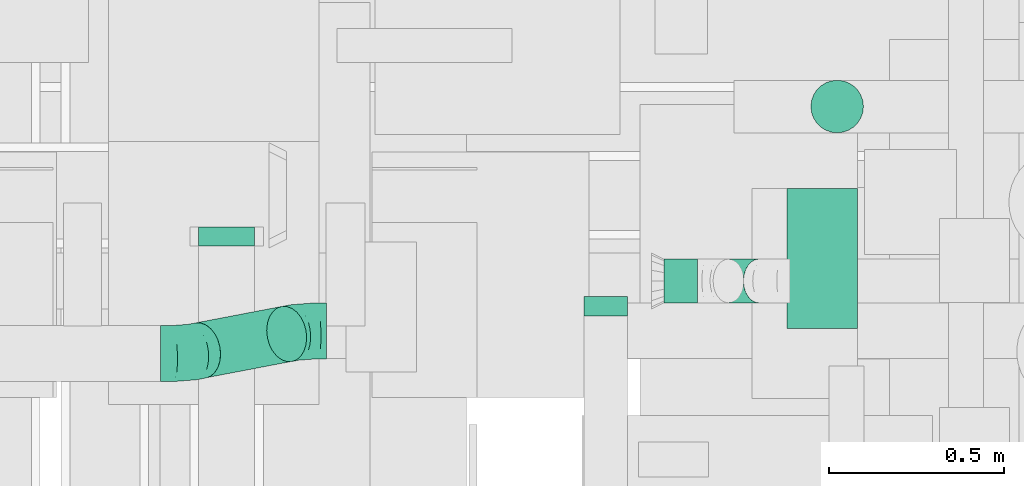
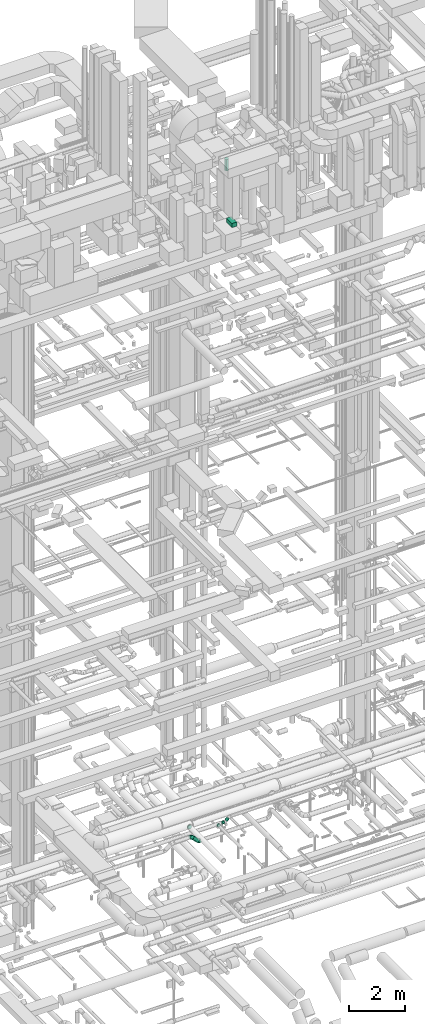
# One storey, part 183 of 337: 5 flow segments, 4 flow fittings.
"""IFC2X3 building model written with IfcOpenShell, lengths in millimetres."""

import ifcopenshell
import ifcopenshell.guid

model = None  # the IFC model being written
_history = None  # IfcOwnerHistory: only IFC2X3 demands one
_inside = {}  # id of a spatial element -> (the spatial element, [elements in it])
_under = {}  # id of a project, library or spatial element -> (it, [spatial elements below it])
_declared = {}  # id of a project -> (the project, [libraries it declares])
_typed = {}  # id of a type object -> (the type object, [elements of that type])
_made_of = {}  # id of a material, layer set ... -> (it, [elements and type objects made of it])


def new_model(schema):
    """Start an empty IFC model of exactly this schema.

    Asked for "IFC4X3", IfcOpenShell would pick the latest addendum, in which some entities
    have other attributes; the version numbers below select the first issue.
    IFC2X3 requires an IfcOwnerHistory on every rooted entity: one is made here for all.
    """
    global model, _history
    if schema == "IFC4X3":
        model = ifcopenshell.file(schema_version=(4, 3, 0, 0))
    else:
        model = ifcopenshell.file(schema=schema)
    _inside.clear()
    _under.clear()
    _declared.clear()
    _typed.clear()
    _made_of.clear()
    _history = None
    if model.schema == "IFC2X3":
        org = make("IfcOrganization", Name="unknown")
        user = make(
            "IfcPersonAndOrganization",
            ThePerson=make("IfcPerson", FamilyName="unknown"),
            TheOrganization=org,
        )
        app = make(
            "IfcApplication",
            ApplicationDeveloper=org,
            Version="unknown",
            ApplicationFullName="unknown",
            ApplicationIdentifier="unknown",
        )
        _history = make(
            "IfcOwnerHistory",
            OwningUser=user,
            OwningApplication=app,
            ChangeAction="ADDED",
            CreationDate=0,
        )
    return model


def make(cls, **values):
    """One entity of the class cls with the attributes given. An attribute that is None is left unset."""
    return model.create_entity(
        cls, **{name: value for name, value in values.items() if value is not None}
    )


def entity(cls, *values):
    """Any entity or typed value of the class cls, its attributes in the order of the schema. None: left unset."""
    e = model.create_entity(cls)
    for i, value in enumerate(values):
        if value is not None:
            e[i] = value
    return e


def rooted(cls, **values):
    """An entity with a GlobalId (a new one), such as an element, a storey or a relation."""
    return make(cls, GlobalId=ifcopenshell.guid.new(), OwnerHistory=_history, **values)


def si_unit(unit_type, name, prefix=None):
    """IfcSIUnit, for example si_unit("LENGTHUNIT", "METRE", prefix="MILLI")."""
    return make("IfcSIUnit", UnitType=unit_type, Prefix=prefix, Name=name)


def converted_unit(unit_type, name, factor, base, dimensions=None, offset=None):
    """IfcConversionBasedUnit, such as the inch: factor (a typed value) times the base unit."""
    return make(
        "IfcConversionBasedUnit"
        if offset is None
        else "IfcConversionBasedUnitWithOffset",
        ConversionOffset=offset,
        Dimensions=None
        if dimensions is None
        else entity("IfcDimensionalExponents", *dimensions),
        UnitType=unit_type,
        Name=name,
        ConversionFactor=make(
            "IfcMeasureWithUnit", ValueComponent=factor, UnitComponent=base
        ),
    )


def derived_unit(unit_type, elements):
    """IfcDerivedUnit: a product of units, each with its exponent."""
    return make(
        "IfcDerivedUnit",
        Elements=[
            make("IfcDerivedUnitElement", Unit=unit, Exponent=power)
            for unit, power in elements
        ],
        UnitType=unit_type,
    )


def assignment(units):
    """IfcUnitAssignment: the units of a project."""
    return None if units is None else make("IfcUnitAssignment", Units=units)


def point(xyz):
    """IfcCartesianPoint."""
    return None if xyz is None else make("IfcCartesianPoint", Coordinates=xyz)


def direction(xyz):
    """IfcDirection."""
    return None if xyz is None else make("IfcDirection", DirectionRatios=xyz)


def frame(location, z_axis=None, x_axis=None):
    """IfcAxis2Placement3D, a coordinate frame: its origin and axes. An axis left out is left unset."""
    return make(
        "IfcAxis2Placement3D",
        Location=point(location),
        Axis=direction(z_axis),
        RefDirection=direction(x_axis),
    )


def frame_2d(location, x_axis=None):
    """IfcAxis2Placement2D, a coordinate frame in the plane: its origin and x axis."""
    return make(
        "IfcAxis2Placement2D", Location=point(location), RefDirection=direction(x_axis)
    )


def origin():
    """The frame at (0, 0, 0) with its axes left unset."""
    return frame((0.0, 0.0, 0.0))


def origin_2d_with_axis():
    """The frame at (0, 0) in the plane with the x axis (1, 0) written out."""
    return frame_2d((0.0, 0.0), x_axis=(1.0, 0.0))


def place(relative_to, where):
    """IfcLocalPlacement: puts the frame where relative to a parent placement (None: the world)."""
    return make(
        "IfcLocalPlacement", PlacementRelTo=relative_to, RelativePlacement=where
    )


def context(
    kind, dimensions, precision=None, world=None, true_north=None, identifier=None
):
    """IfcGeometricRepresentationContext, for example the 3D "Model" context."""
    return make(
        "IfcGeometricRepresentationContext",
        ContextIdentifier=identifier,
        ContextType=kind,
        CoordinateSpaceDimension=dimensions,
        Precision=precision,
        WorldCoordinateSystem=world,
        TrueNorth=true_north,
    )


def subcontext(parent, identifier, kind, view, scale=None):
    """IfcGeometricRepresentationSubContext, for example "Body" below "Model"."""
    return make(
        "IfcGeometricRepresentationSubContext",
        ContextIdentifier=identifier,
        ContextType=kind,
        ParentContext=parent,
        TargetScale=scale,
        TargetView=view,
    )


def project(units=None, contexts=None):
    """IfcProject with its units and contexts."""
    return rooted(
        "IfcProject",
        Name="project",
        RepresentationContexts=contexts,
        UnitsInContext=assignment(units),
    )


def spatial(cls, under=None, at=None, **own):
    """A site, building, storey or space (cls), placed at a placement, below another one or the project."""
    s = rooted(cls, ObjectPlacement=at, **own)
    if under is not None:
        _under.setdefault(under.id(), (under, []))[1].append(s)
    return s


def profile(cls, at=None, kind="AREA", **sizes):
    """A parametric profile (cls). Its sizes go by their IFC names, for example OverallWidth=200.0."""
    return make(cls, ProfileType=kind, Position=at, **sizes)


def rectangle(**sizes):
    """IfcRectangleProfileDef."""
    return profile("IfcRectangleProfileDef", **sizes)


def circle(**sizes):
    """IfcCircleProfileDef."""
    return profile("IfcCircleProfileDef", **sizes)


def extrude(swept, where, along, depth):
    """IfcExtrudedAreaSolid: the profile swept, set in the frame where, extruded along a direction by depth."""
    return make(
        "IfcExtrudedAreaSolid",
        SweptArea=swept,
        Position=where,
        ExtrudedDirection=direction(along),
        Depth=depth,
    )


def faces_of(points, faces, orient=None, outer=None):
    """IfcFace entities. A face is a list of loops; a loop is a list of indices into points, from 0.

    orient and outer hold one flag for each loop. By default every Orientation is true, the
    first loop of a face is its IfcFaceOuterBound and the others are IfcFaceBound.
    """
    made = []
    for i, loops in enumerate(faces):
        bounds = []
        for j, loop in enumerate(loops):
            is_outer = j == 0 if outer is None else outer[i][j]
            bounds.append(
                make(
                    "IfcFaceOuterBound" if is_outer else "IfcFaceBound",
                    Bound=make("IfcPolyLoop", Polygon=[points[k] for k in loop]),
                    Orientation=True if orient is None else orient[i][j],
                )
            )
        made.append(make("IfcFace", Bounds=bounds))
    return made


def faceted_brep(points, faces, orient=None, outer=None, voids=None):
    """IfcFacetedBrep: a solid bounded by flat faces; with voids (closed shells), ...WithVoids."""
    shared = [point(p) for p in points]
    hull = make("IfcClosedShell", CfsFaces=faces_of(shared, faces, orient, outer))
    if voids is None:
        return make("IfcFacetedBrep", Outer=hull)
    return make(
        "IfcFacetedBrepWithVoids",
        Outer=hull,
        Voids=[
            make(cls, CfsFaces=faces_of(shared, fs, o, b)) for cls, fs, o, b in voids
        ],
    )


def shape(context_of_items, identifier, shape_type, items):
    """IfcShapeRepresentation: the items that make up one representation, for example the "Body"."""
    return make(
        "IfcShapeRepresentation",
        ContextOfItems=context_of_items,
        RepresentationIdentifier=identifier,
        RepresentationType=shape_type,
        Items=items,
    )


def source(mapping_origin, context_of_items, identifier, shape_type, items):
    """IfcRepresentationMap: a shape defined once, which mapped items show again and again."""
    return make(
        "IfcRepresentationMap",
        MappingOrigin=mapping_origin,
        MappedRepresentation=shape(context_of_items, identifier, shape_type, items),
    )


def transform(
    local_origin,
    x_axis=None,
    y_axis=None,
    z_axis=None,
    scale=None,
    scale2=None,
    scale3=None,
    uniform=True,
):
    """IfcCartesianTransformationOperator3D, or its non-uniform kind. x_axis, y_axis, z_axis: its Axis1, 2, 3."""
    if uniform:
        return make(
            "IfcCartesianTransformationOperator3D",
            Axis1=direction(x_axis),
            Axis2=direction(y_axis),
            LocalOrigin=point(local_origin),
            Scale=scale,
            Axis3=direction(z_axis),
        )
    return make(
        "IfcCartesianTransformationOperator3DnonUniform",
        Axis1=direction(x_axis),
        Axis2=direction(y_axis),
        LocalOrigin=point(local_origin),
        Scale=scale,
        Axis3=direction(z_axis),
        Scale2=scale2,
        Scale3=scale3,
    )


def mapped(mapping_source, mapping_target):
    """IfcMappedItem: shows the shape of a source again, moved by a transform."""
    return make(
        "IfcMappedItem", MappingSource=mapping_source, MappingTarget=mapping_target
    )


def material(Name=None, Category=None):
    """IfcMaterial."""
    return make("IfcMaterial", Name=Name, Category=Category)


def made_of(thing, what):
    """Note that an element or type object is made of a material, layer set ...; save() writes the relation."""
    if what is not None:
        _made_of.setdefault(what.id(), (what, []))[1].append(thing)
    return thing


def type_object(cls, material=None, **own):
    """A type object (cls), such as IfcWallType, which elements share."""
    return made_of(rooted(cls, **own), material)


def type_shapes(of_type, sources):
    """Give a type object the sources (RepresentationMaps) that its elements show as mapped items."""
    of_type.RepresentationMaps = sources


def element(
    cls,
    number,
    at=None,
    inside=None,
    cuts=None,
    type_object=None,
    material=None,
    context=None,
    identifier="Body",
    shape_type=None,
    held_by="IfcProductDefinitionShape",
    body=None,
    shapes=None,
    **own,
):
    """One element of the class cls, such as IfcWall. Its Tag is "e" and its number.

    at: its placement. inside: the storey or other place that contains it. cuts: it is an
    opening in that element (IfcRelVoidsElement). A single representation is given by context,
    identifier, shape_type and body (its items); several are given by shapes. held_by: the class
    of the entity that holds the representations. save() writes the other relations.
    """
    e = rooted(cls, Tag="e%d" % number, ObjectPlacement=at, **own)
    if body is not None:
        shapes = [shape(context, identifier, shape_type, body)]
    if shapes is not None:
        e.Representation = make(held_by, Representations=shapes)
    if inside is not None:
        _inside.setdefault(inside.id(), (inside, []))[1].append(e)
    if cuts is not None:
        rooted(
            "IfcRelVoidsElement", RelatingBuildingElement=cuts, RelatedOpeningElement=e
        )
    if type_object is not None:
        _typed.setdefault(type_object.id(), (type_object, []))[1].append(e)
    return made_of(e, material)


def aggregate(whole, parts):
    """IfcRelAggregates: a whole, such as a stair, and the parts it consists of."""
    return rooted("IfcRelAggregates", RelatingObject=whole, RelatedObjects=parts)


def save(model, path):
    """Write the relations noted so far, then the file.

    IfcRelAggregates (storeys below a building ...), IfcRelContainedInSpatialStructure (elements
    in a storey), IfcRelDefinesByType, IfcRelAssociatesMaterial and IfcRelDeclares: one each for
    every whole, place, type object, material and project.
    """
    for whole, parts in _under.values():
        aggregate(whole, parts)
    for where, things in _inside.values():
        rooted(
            "IfcRelContainedInSpatialStructure",
            RelatedElements=things,
            RelatingStructure=where,
        )
    for kind, things in _typed.values():
        rooted("IfcRelDefinesByType", RelatedObjects=things, RelatingType=kind)
    for what, things in _made_of.values():
        rooted("IfcRelAssociatesMaterial", RelatedObjects=things, RelatingMaterial=what)
    for by, libraries in _declared.values():
        rooted("IfcRelDeclares", RelatingContext=by, RelatedDefinitions=libraries)
    model.write(path)


model = new_model("IFC2X3")

# Units and contexts
model_context = context("Model", 3, precision=0.01, world=origin(), true_north=direction((6.12303176911189e-17, 1.0)))
body_context = subcontext(model_context, "Body", "Model", "MODEL_VIEW")
ifc_project = project(units=[si_unit("LENGTHUNIT", "METRE", prefix="MILLI"), si_unit("AREAUNIT", "SQUARE_METRE"), si_unit("VOLUMEUNIT", "CUBIC_METRE"), converted_unit("PLANEANGLEUNIT", "DEGREE", entity("IfcRatioMeasure", 0.0174532925199433), si_unit("PLANEANGLEUNIT", "RADIAN"), dimensions=[0, 0, 0, 0, 0, 0, 0]), si_unit("MASSUNIT", "GRAM", prefix="KILO"), derived_unit("MASSDENSITYUNIT", [(si_unit("MASSUNIT", "GRAM", prefix="KILO"), 1), (si_unit("LENGTHUNIT", "METRE"), -3)]), derived_unit("MOMENTOFINERTIAUNIT", [(si_unit("LENGTHUNIT", "METRE"), 4)]), si_unit("TIMEUNIT", "SECOND"), si_unit("FREQUENCYUNIT", "HERTZ"), si_unit("THERMODYNAMICTEMPERATUREUNIT", "DEGREE_CELSIUS"), derived_unit("THERMALTRANSMITTANCEUNIT", [(si_unit("MASSUNIT", "GRAM", prefix="KILO"), 1), (si_unit("THERMODYNAMICTEMPERATUREUNIT", "KELVIN"), -1), (si_unit("TIMEUNIT", "SECOND"), -3)]), derived_unit("VOLUMETRICFLOWRATEUNIT", [(si_unit("LENGTHUNIT", "METRE"), 3), (si_unit("TIMEUNIT", "SECOND"), -1)]), derived_unit("MASSFLOWRATEUNIT", [(si_unit("MASSUNIT", "GRAM", prefix="KILO"), 1), (si_unit("TIMEUNIT", "SECOND"), -1)]), derived_unit("ROTATIONALFREQUENCYUNIT", [(si_unit("TIMEUNIT", "SECOND"), -1)]), si_unit("ELECTRICCURRENTUNIT", "AMPERE"), si_unit("ELECTRICVOLTAGEUNIT", "VOLT"), si_unit("POWERUNIT", "WATT"), si_unit("FORCEUNIT", "NEWTON", prefix="KILO"), si_unit("ILLUMINANCEUNIT", "LUX"), si_unit("LUMINOUSFLUXUNIT", "LUMEN"), si_unit("LUMINOUSINTENSITYUNIT", "CANDELA"), derived_unit("USERDEFINED", [(si_unit("MASSUNIT", "GRAM", prefix="KILO"), -1), (si_unit("LENGTHUNIT", "METRE"), -2), (si_unit("TIMEUNIT", "SECOND"), 3), (si_unit("LUMINOUSFLUXUNIT", "LUMEN"), 1)]), derived_unit("LINEARVELOCITYUNIT", [(si_unit("LENGTHUNIT", "METRE"), 1), (si_unit("TIMEUNIT", "SECOND"), -1)]), si_unit("PRESSUREUNIT", "PASCAL"), derived_unit("USERDEFINED", [(si_unit("LENGTHUNIT", "METRE"), -2), (si_unit("MASSUNIT", "GRAM", prefix="KILO"), 1), (si_unit("TIMEUNIT", "SECOND"), -2)]), derived_unit("LINEARFORCEUNIT", [(si_unit("MASSUNIT", "GRAM", prefix="KILO"), 1), (si_unit("LENGTHUNIT", "METRE"), 1), (si_unit("TIMEUNIT", "SECOND"), -2), (si_unit("LENGTHUNIT", "METRE"), -1)]), derived_unit("PLANARFORCEUNIT", [(si_unit("MASSUNIT", "GRAM", prefix="KILO"), 1), (si_unit("LENGTHUNIT", "METRE"), 1), (si_unit("TIMEUNIT", "SECOND"), -2), (si_unit("LENGTHUNIT", "METRE"), -2)])], contexts=[model_context])

# Site, building, storey
site_placement = place(None, origin())
site = spatial("IfcSite", under=ifc_project, at=site_placement, CompositionType="ELEMENT")
building_placement = place(site_placement, origin())
building = spatial("IfcBuilding", under=site, at=building_placement, CompositionType="ELEMENT")
storey_placement = place(building_placement, origin())
storey = spatial("IfcBuildingStorey", under=building, at=storey_placement, CompositionType="ELEMENT", Elevation=0.0)

# Flow segments
duct_segment_type_1 = type_object("IfcDuctSegmentType", PredefinedType="NOTDEFINED")
flow_segment_1_placement = place(storey_placement, frame((52010.61, 8206.69, 29120.0)))
element("IfcFlowSegment", 1, at=flow_segment_1_placement, inside=storey, type_object=duct_segment_type_1, context=body_context, shape_type="SweptSolid", body=[
    extrude(rectangle(XDim=200.000000000007, YDim=400.0, at=origin_2d_with_axis()), frame((100.0, 200.0, 0.0)), (0.0, 0.0, 1.0), 177.000000000337),
])
duct_segment_type_2 = type_object("IfcDuctSegmentType", PredefinedType="NOTDEFINED")
flow_segment_2_placement = place(storey_placement, frame((52076.59, 8763.9, 31208.0)))
element("IfcFlowSegment", 2, at=flow_segment_2_placement, inside=storey, type_object=duct_segment_type_2, context=body_context, shape_type="SweptSolid", body=[
    extrude(circle(Radius=75.0, at=origin_2d_with_axis()), frame((76.6, 76.6, 0.0)), (0.0, 0.0, 1.0), 497.002731163141),
])
flow_segment_3_placement = place(storey_placement, frame((50277.05, 8063.8, 2888.36)))
element("IfcFlowSegment", 3, at=flow_segment_3_placement, inside=storey, type_object=duct_segment_type_2, context=body_context, shape_type="SweptSolid", body=[
    extrude(circle(Radius=80.0, at=origin_2d_with_axis()), frame((304.61, 127.24, 58.67), z_axis=(-0.700733092058318, -0.133963679364098, 0.700733092058326), x_axis=(-0.18777580730125, 0.98221191511423, 0.0)), (0.0, 0.0, 1.0), 350.972539327525),
])
flow_segment_4_placement = place(storey_placement, frame((51658.34, 8278.42, 3175.9)))
element("IfcFlowSegment", 4, at=flow_segment_4_placement, inside=storey, type_object=duct_segment_type_2, context=body_context, shape_type="SweptSolid", body=[
    extrude(circle(Radius=62.5, at=origin_2d_with_axis()), frame((0.0, 64.1, 64.1), z_axis=(1.0, 0.0, 0.0), x_axis=(0.0, -1.0, 0.0)), (0.0, 0.0, 1.0), 96.4430691768214),
])
flow_segment_5_placement = place(storey_placement, frame((51797.39, 8278.42, 3230.82)))
element("IfcFlowSegment", 5, at=flow_segment_5_placement, inside=storey, type_object=duct_segment_type_2, context=body_context, shape_type="SweptSolid", body=[
    extrude(circle(Radius=62.5, at=origin_2d_with_axis()), frame((45.79, 64.1, 45.79), z_axis=(0.707106523092433, 0.0, 0.707107039280568), x_axis=(0.0, -1.0, 0.0)), (0.0, 0.0, 1.0), 122.720643343335),
])

# Flow fittings
ifc_material = material()
duct_fitting_type_1 = type_object("IfcDuctFittingType", PredefinedType="NOTDEFINED", material=ifc_material)
shared_shape_1 = source(origin(), body_context, "Body", "Brep", [
    faceted_brep([(20.0, 16.18, -60.37), (20.0, 31.25, -54.13), (20.0, 44.19, -44.19), (20.0, 54.13, -31.25), (20.0, 60.37, -16.18), (20.0, 62.5, 0.0), (20.0, 60.37, 16.18), (20.0, 54.13, 31.25), (20.0, 44.19, 44.19), (20.0, 31.25, 54.13), (20.0, 16.18, 60.37), (20.0, 0.0, 62.5), (20.0, -16.18, 60.37), (20.0, -31.25, 54.13), (20.0, -44.19, 44.19), (20.0, -54.13, 31.25), (20.0, -60.37, 16.18), (20.0, -62.5, 0.0), (20.0, -60.37, -16.18), (20.0, -54.13, -31.25), (20.0, -44.19, -44.19), (20.0, -31.25, -54.13), (20.0, -16.18, -60.37), (20.0, 0.0, -62.5), (0.0, 0.0, 62.5), (0.0, 16.18, 60.37), (-36.16, 16.18, 60.37), (-36.16, 0.0, 62.5), (0.0, 31.25, 54.13), (-36.16, 31.25, 54.13), (0.0, 44.19, 44.19), (-36.16, 44.19, 44.19), (0.0, 54.13, 31.25), (0.0, 60.37, 16.18), (-36.16, 60.37, 16.18), (-36.16, 54.13, 31.25), (0.0, 62.5, 0.0), (-36.16, 62.5, 0.0), (0.0, 60.37, -16.18), (-36.16, 60.37, -16.18), (0.0, 54.13, -31.25), (-36.16, 54.13, -31.25), (0.0, 44.19, -44.19), (-36.16, 44.19, -44.19), (0.0, 31.25, -54.13), (0.0, 16.18, -60.37), (-36.16, 16.18, -60.37), (-36.16, 31.25, -54.13), (0.0, 0.0, -62.5), (-36.16, 0.0, -62.5), (0.0, -16.18, -60.37), (-36.16, -16.18, -60.37), (0.0, -31.25, -54.13), (-36.16, -31.25, -54.13), (0.0, -44.19, -44.19), (-36.16, -44.19, -44.19), (0.0, -54.13, -31.25), (0.0, -60.37, -16.18), (-36.16, -60.37, -16.18), (-36.16, -54.13, -31.25), (0.0, -62.5, 0.0), (-36.16, -62.5, 0.0), (0.0, -60.37, 16.18), (-36.16, -60.37, 16.18), (0.0, -54.13, 31.25), (-36.16, -54.13, 31.25), (0.0, -44.19, 44.19), (-36.16, -44.19, 44.19), (0.0, -31.25, 54.13), (0.0, -16.18, 60.37), (-36.16, -16.18, 60.37), (-36.16, -31.25, 54.13)], [[[0, 1, 2, 3, 4, 5, 6, 7, 8, 9, 10, 11, 12, 13, 14, 15, 16, 17, 18, 19, 20, 21, 22, 23]], [[24, 11, 10, 25, 26, 27]], [[25, 10, 9, 28, 29, 26]], [[28, 9, 8, 30, 31, 29]], [[32, 7, 6, 33, 34, 35]], [[33, 6, 5, 36, 37, 34]], [[30, 8, 7, 32, 35, 31]], [[36, 5, 4, 38, 39, 37]], [[38, 4, 3, 40, 41, 39]], [[40, 3, 2, 42, 43, 41]], [[44, 1, 0, 45, 46, 47]], [[45, 0, 23, 48, 49, 46]], [[42, 2, 1, 44, 47, 43]], [[48, 23, 22, 50, 51, 49]], [[50, 22, 21, 52, 53, 51]], [[52, 21, 20, 54, 55, 53]], [[56, 19, 18, 57, 58, 59]], [[57, 18, 17, 60, 61, 58]], [[54, 20, 19, 56, 59, 55]], [[60, 17, 16, 62, 63, 61]], [[62, 16, 15, 64, 65, 63]], [[64, 15, 14, 66, 67, 65]], [[68, 13, 12, 69, 70, 71]], [[69, 12, 11, 24, 27, 70]], [[66, 14, 13, 68, 71, 67]], [[49, 51, 53, 55, 59, 58, 61, 63, 65, 67, 71, 70, 27, 26, 29, 31, 35, 34, 37, 39, 41, 43, 47, 46]]]),
])
type_shapes(duct_fitting_type_1, [shared_shape_1])
flow_fitting_1_placement = place(storey_placement, frame((51492.68, 8262.51, 3240.0), z_axis=(0.0, 0.0, -1.0), x_axis=(0.0, -1.0, 0.0)))
element("IfcFlowFitting", 6, at=flow_fitting_1_placement, inside=storey, type_object=duct_fitting_type_1, material=ifc_material, context=body_context, shape_type="MappedRepresentation", body=[
    mapped(shared_shape_1, transform((0.0, 0.0, 0.0), scale=1.0)),
])
duct_fitting_type_2 = type_object("IfcDuctFittingType", PredefinedType="NOTDEFINED", material=ifc_material)
shared_shape_2 = source(origin(), body_context, "Body", "Brep", [
    faceted_brep([(20.0, 20.71, -77.27), (20.0, 40.0, -69.28), (20.0, 56.57, -56.57), (20.0, 69.28, -40.0), (20.0, 77.27, -20.71), (20.0, 80.0, 0.0), (20.0, 77.27, 20.71), (20.0, 69.28, 40.0), (20.0, 56.57, 56.57), (20.0, 40.0, 69.28), (20.0, 20.71, 77.27), (20.0, 0.0, 80.0), (20.0, -20.71, 77.27), (20.0, -40.0, 69.28), (20.0, -56.57, 56.57), (20.0, -69.28, 40.0), (20.0, -77.27, 20.71), (20.0, -80.0, 0.0), (20.0, -77.27, -20.71), (20.0, -69.28, -40.0), (20.0, -56.57, -56.57), (20.0, -40.0, -69.28), (20.0, -20.71, -77.27), (20.0, 0.0, -80.0), (0.0, 0.0, 80.0), (0.0, 20.71, 77.27), (-35.05, 20.71, 77.27), (-35.05, 0.0, 80.0), (0.0, 40.0, 69.28), (-35.05, 40.0, 69.28), (0.0, 56.57, 56.57), (-35.05, 56.57, 56.57), (0.0, 69.28, 40.0), (0.0, 77.27, 20.71), (-35.05, 77.27, 20.71), (-35.05, 69.28, 40.0), (0.0, 80.0, 0.0), (-35.05, 80.0, 0.0), (0.0, 77.27, -20.71), (-35.05, 77.27, -20.71), (0.0, 69.28, -40.0), (-35.05, 69.28, -40.0), (0.0, 56.57, -56.57), (-35.05, 56.57, -56.57), (0.0, 40.0, -69.28), (0.0, 20.71, -77.27), (-35.05, 20.71, -77.27), (-35.05, 40.0, -69.28), (0.0, 0.0, -80.0), (-35.05, 0.0, -80.0), (0.0, -20.71, -77.27), (-35.05, -20.71, -77.27), (0.0, -40.0, -69.28), (-35.05, -40.0, -69.28), (0.0, -56.57, -56.57), (-35.05, -56.57, -56.57), (0.0, -69.28, -40.0), (0.0, -77.27, -20.71), (-35.05, -77.27, -20.71), (-35.05, -69.28, -40.0), (0.0, -80.0, 0.0), (-35.05, -80.0, 0.0), (0.0, -77.27, 20.71), (-35.05, -77.27, 20.71), (0.0, -69.28, 40.0), (-35.05, -69.28, 40.0), (0.0, -56.57, 56.57), (-35.05, -56.57, 56.57), (0.0, -40.0, 69.28), (0.0, -20.71, 77.27), (-35.05, -20.71, 77.27), (-35.05, -40.0, 69.28)], [[[0, 1, 2, 3, 4, 5, 6, 7, 8, 9, 10, 11, 12, 13, 14, 15, 16, 17, 18, 19, 20, 21, 22, 23]], [[24, 11, 10, 25, 26, 27]], [[25, 10, 9, 28, 29, 26]], [[28, 9, 8, 30, 31, 29]], [[32, 7, 6, 33, 34, 35]], [[33, 6, 5, 36, 37, 34]], [[30, 8, 7, 32, 35, 31]], [[36, 5, 4, 38, 39, 37]], [[38, 4, 3, 40, 41, 39]], [[40, 3, 2, 42, 43, 41]], [[44, 1, 0, 45, 46, 47]], [[45, 0, 23, 48, 49, 46]], [[42, 2, 1, 44, 47, 43]], [[48, 23, 22, 50, 51, 49]], [[50, 22, 21, 52, 53, 51]], [[52, 21, 20, 54, 55, 53]], [[56, 19, 18, 57, 58, 59]], [[57, 18, 17, 60, 61, 58]], [[54, 20, 19, 56, 59, 55]], [[60, 17, 16, 62, 63, 61]], [[62, 16, 15, 64, 65, 63]], [[64, 15, 14, 66, 67, 65]], [[68, 13, 12, 69, 70, 71]], [[69, 12, 11, 24, 27, 70]], [[66, 14, 13, 68, 71, 67]], [[49, 51, 53, 55, 59, 58, 61, 63, 65, 67, 71, 70, 27, 26, 29, 31, 35, 34, 37, 39, 41, 43, 47, 46]]]),
])
type_shapes(duct_fitting_type_2, [shared_shape_2])
flow_fitting_2_placement = place(storey_placement, frame((50409.85, 8461.67, 3425.0), z_axis=(0.0, 0.0, -1.0), x_axis=(0.0, -1.0, 0.0)))
element("IfcFlowFitting", 7, at=flow_fitting_2_placement, inside=storey, type_object=duct_fitting_type_2, material=ifc_material, context=body_context, shape_type="MappedRepresentation", body=[
    mapped(shared_shape_2, transform((0.0, 0.0, 0.0), scale=1.0)),
])
duct_fitting_type_3 = type_object("IfcDuctFittingType", PredefinedType="NOTDEFINED", material=ifc_material)
shared_shape_3 = source(origin(), body_context, "Body", "Brep", [
    faceted_brep([(-67.12, 0.0, -80.0), (-67.12, -20.71, -77.27), (-67.12, -40.0, -69.28), (-67.12, -56.57, -56.57), (-67.12, -69.28, -40.0), (-67.12, -77.27, -20.71), (-67.12, -80.0, 0.0), (-67.12, -77.27, 20.71), (-67.12, -69.28, 40.0), (-67.12, -56.57, 56.57), (-67.12, -40.0, 69.28), (-67.12, -20.71, 77.27), (-67.12, 0.0, 80.0), (-67.12, 20.71, 77.27), (-67.12, 40.0, 69.28), (-67.12, 56.57, 56.57), (-67.12, 69.28, 40.0), (-67.12, 77.27, 20.71), (-67.12, 80.0, 0.0), (-67.12, 77.27, -20.71), (-67.12, 69.28, -40.0), (-67.12, 56.57, -56.57), (-67.12, 40.0, -69.28), (-67.12, 20.71, -77.27), (-39.08, 20.71, 77.27), (-42.97, 40.0, 69.28), (-34.92, 0.0, 80.0), (-46.3, 56.57, 56.57), (-50.47, 77.27, 20.71), (-51.02, 80.0, 0.0), (-48.86, 69.28, 40.0), (-48.86, 69.28, -40.0), (-46.3, 56.57, -56.57), (-50.47, 77.27, -20.71), (-39.08, 20.71, -77.27), (-34.92, 0.0, -80.0), (-42.97, 40.0, -69.28), (-30.75, -20.71, -77.27), (-26.87, -40.0, -69.28), (-23.53, -56.57, -56.57), (-20.97, -69.28, -40.0), (-19.37, -77.27, -20.71), (-18.82, -80.0, 0.0), (-19.37, -77.27, 20.71), (-20.97, -69.28, 40.0), (-23.53, -56.57, 56.57), (-26.87, -40.0, 69.28), (-30.75, -20.71, 77.27), (12.62, 42.39, 77.27), (1.57, 58.68, 69.28), (24.47, 24.91, 80.0), (-7.91, 72.67, 56.57), (-15.19, 83.41, 40.0), (-19.76, 90.15, 20.71), (-21.32, 92.46, 0.0), (-19.76, 90.15, -20.71), (-15.19, 83.41, -40.0), (-7.91, 72.67, -56.57), (12.62, 42.39, -77.27), (24.47, 24.91, -80.0), (1.57, 58.68, -69.28), (36.32, 7.43, -77.27), (47.36, -8.86, -69.28), (56.85, -22.85, -56.57), (64.13, -33.58, -40.0), (68.7, -40.33, -20.71), (70.26, -42.63, 0.0), (68.7, -40.33, 20.71), (64.13, -33.58, 40.0), (56.85, -22.85, 56.57), (47.36, -8.86, 69.28), (36.32, 7.43, 77.27), (47.03, 47.88, 80.0), (32.26, 62.39, 77.27), (18.49, 75.91, 69.28), (6.67, 87.52, 56.57), (-2.4, 96.43, 40.0), (-8.1, 102.03, 20.71), (-10.04, 103.94, 0.0), (-8.1, 102.03, -20.71), (-2.4, 96.43, -40.0), (6.67, 87.52, -56.57), (18.49, 75.91, -69.28), (32.26, 62.39, -77.27), (47.03, 47.88, -80.0), (61.8, 33.37, -77.27), (75.57, 19.85, -69.28), (87.39, 8.24, -56.57), (96.46, -0.67, -40.0), (102.16, -6.27, -20.71), (104.1, -8.18, 0.0), (102.16, -6.27, 20.71), (96.46, -0.67, 40.0), (87.39, 8.24, 56.57), (61.8, 33.37, 77.27), (75.57, 19.85, 69.28)], [[[0, 1, 2, 3, 4, 5, 6, 7, 8, 9, 10, 11, 12, 13, 14, 15, 16, 17, 18, 19, 20, 21, 22, 23]], [[24, 25, 14, 13]], [[26, 24, 13, 12]], [[14, 25, 27, 15]], [[28, 29, 18, 17]], [[30, 28, 17, 16]], [[15, 27, 30, 16]], [[20, 31, 32, 21]], [[33, 31, 20, 19]], [[18, 29, 33, 19]], [[34, 35, 0, 23]], [[36, 34, 23, 22]], [[32, 36, 22, 21]], [[2, 1, 37, 38]], [[3, 2, 38, 39]], [[0, 35, 37, 1]], [[5, 4, 40, 41]], [[6, 5, 41, 42]], [[3, 39, 40, 4]], [[6, 42, 43, 7]], [[7, 43, 44, 8]], [[8, 44, 45, 9]], [[10, 46, 47, 11]], [[11, 47, 26, 12]], [[9, 45, 46, 10]], [[48, 49, 25, 24]], [[50, 48, 24, 26]], [[27, 25, 49, 51]], [[52, 53, 28, 30]], [[51, 52, 30, 27]], [[29, 28, 53, 54]], [[55, 56, 31, 33]], [[54, 55, 33, 29]], [[32, 31, 56, 57]], [[58, 59, 35, 34]], [[60, 58, 34, 36]], [[57, 60, 36, 32]], [[37, 35, 59, 61]], [[38, 37, 61, 62]], [[39, 38, 62, 63]], [[41, 40, 64, 65]], [[42, 41, 65, 66]], [[63, 64, 40, 39]], [[43, 42, 66, 67]], [[44, 43, 67, 68]], [[68, 69, 45, 44]], [[46, 45, 69, 70]], [[47, 46, 70, 71]], [[26, 47, 71, 50]], [[48, 50, 72, 73]], [[49, 48, 73, 74]], [[51, 49, 74, 75]], [[53, 52, 76, 77]], [[54, 53, 77, 78]], [[51, 75, 76, 52]], [[54, 78, 79, 55]], [[55, 79, 80, 56]], [[56, 80, 81, 57]], [[60, 82, 83, 58]], [[58, 83, 84, 59]], [[60, 57, 81, 82]], [[59, 84, 85, 61]], [[61, 85, 86, 62]], [[62, 86, 87, 63]], [[64, 88, 89, 65]], [[65, 89, 90, 66]], [[63, 87, 88, 64]], [[67, 66, 90, 91]], [[68, 67, 91, 92]], [[69, 68, 92, 93]], [[94, 72, 50, 71]], [[95, 94, 71, 70]], [[93, 95, 70, 69]], [[83, 82, 81, 80, 79, 78, 77, 76, 75, 74, 73, 72, 94, 95, 93, 92, 91, 90, 89, 88, 87, 86, 85, 84]]]),
])
type_shapes(duct_fitting_type_3, [shared_shape_3])
for number, where, z_axis, x_axis in (
    (8, (50288.69, 8135.02, 3240.0), (0.0, 0.982211915114232, 0.187775807301239), (1.0, 0.0, 0.0)),
    (9, (50628.69, 8200.02, 2900.0), (0.0, -0.982211915114232, -0.187775807301239), (0.700733092058282, 0.133963679364091, -0.700733092058363)),
):
    element("IfcFlowFitting", number, at=place(storey_placement, frame(where, z_axis=z_axis, x_axis=x_axis)), inside=storey, type_object=duct_fitting_type_3, material=ifc_material, context=body_context, shape_type="MappedRepresentation", body=[
        mapped(shared_shape_3, transform((0.0, 0.0, 0.0), scale=1.0)),
    ])

save(model, "model.ifc")
